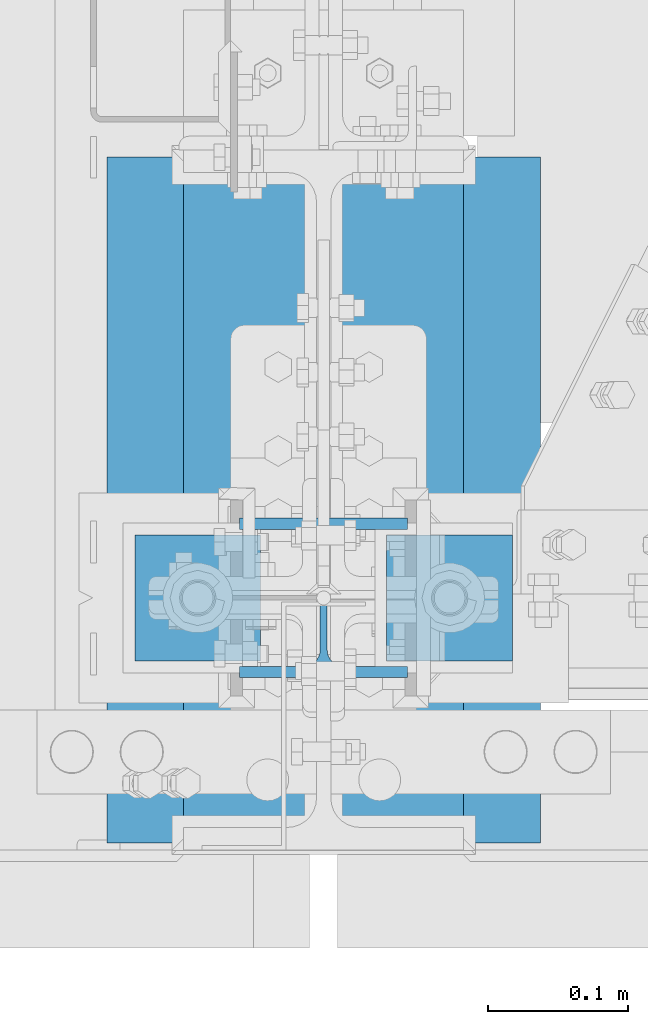
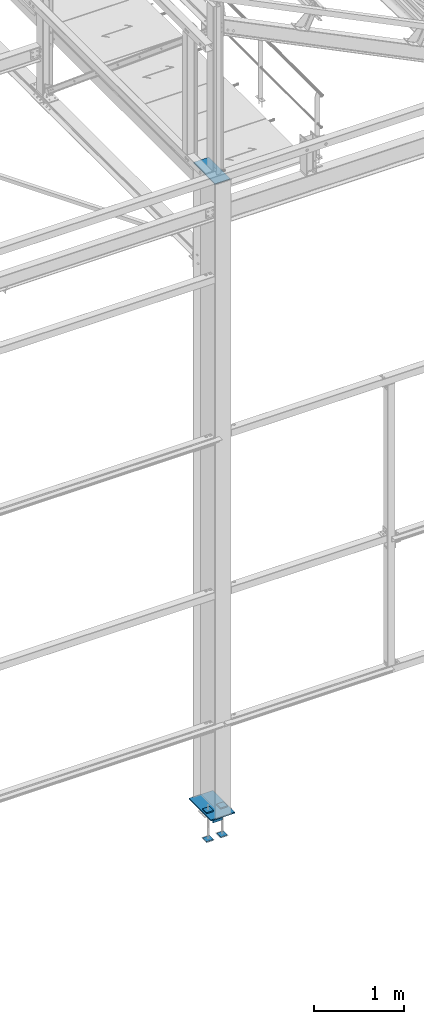
# One storey, part 102 of 496: 7 beams, 2 elements without a shape of their own.
"""IFC2X3 building model written with IfcOpenShell, lengths in millimetres."""

import ifcopenshell
import ifcopenshell.guid

model = None  # the IFC model being written
_history = None  # IfcOwnerHistory: only IFC2X3 demands one
_inside = {}  # id of a spatial element -> (the spatial element, [elements in it])
_under = {}  # id of a project, library or spatial element -> (it, [spatial elements below it])
_declared = {}  # id of a project -> (the project, [libraries it declares])
_typed = {}  # id of a type object -> (the type object, [elements of that type])
_made_of = {}  # id of a material, layer set ... -> (it, [elements and type objects made of it])


def new_model(schema):
    """Start an empty IFC model of exactly this schema.

    Asked for "IFC4X3", IfcOpenShell would pick the latest addendum, in which some entities
    have other attributes; the version numbers below select the first issue.
    IFC2X3 requires an IfcOwnerHistory on every rooted entity: one is made here for all.
    """
    global model, _history
    if schema == "IFC4X3":
        model = ifcopenshell.file(schema_version=(4, 3, 0, 0))
    else:
        model = ifcopenshell.file(schema=schema)
    _inside.clear()
    _under.clear()
    _declared.clear()
    _typed.clear()
    _made_of.clear()
    _history = None
    if model.schema == "IFC2X3":
        org = make("IfcOrganization", Name="unknown")
        user = make(
            "IfcPersonAndOrganization",
            ThePerson=make("IfcPerson", FamilyName="unknown"),
            TheOrganization=org,
        )
        app = make(
            "IfcApplication",
            ApplicationDeveloper=org,
            Version="unknown",
            ApplicationFullName="unknown",
            ApplicationIdentifier="unknown",
        )
        _history = make(
            "IfcOwnerHistory",
            OwningUser=user,
            OwningApplication=app,
            ChangeAction="ADDED",
            CreationDate=0,
        )
    return model


def make(cls, **values):
    """One entity of the class cls with the attributes given. An attribute that is None is left unset."""
    return model.create_entity(
        cls, **{name: value for name, value in values.items() if value is not None}
    )


def rooted(cls, **values):
    """An entity with a GlobalId (a new one), such as an element, a storey or a relation."""
    return make(cls, GlobalId=ifcopenshell.guid.new(), OwnerHistory=_history, **values)


def si_unit(unit_type, name, prefix=None):
    """IfcSIUnit, for example si_unit("LENGTHUNIT", "METRE", prefix="MILLI")."""
    return make("IfcSIUnit", UnitType=unit_type, Prefix=prefix, Name=name)


def assignment(units):
    """IfcUnitAssignment: the units of a project."""
    return None if units is None else make("IfcUnitAssignment", Units=units)


def point(xyz):
    """IfcCartesianPoint."""
    return None if xyz is None else make("IfcCartesianPoint", Coordinates=xyz)


def direction(xyz):
    """IfcDirection."""
    return None if xyz is None else make("IfcDirection", DirectionRatios=xyz)


def frame(location, z_axis=None, x_axis=None):
    """IfcAxis2Placement3D, a coordinate frame: its origin and axes. An axis left out is left unset."""
    return make(
        "IfcAxis2Placement3D",
        Location=point(location),
        Axis=direction(z_axis),
        RefDirection=direction(x_axis),
    )


def frame_2d(location, x_axis=None):
    """IfcAxis2Placement2D, a coordinate frame in the plane: its origin and x axis."""
    return make(
        "IfcAxis2Placement2D", Location=point(location), RefDirection=direction(x_axis)
    )


def origin_with_axes():
    """The frame at (0, 0, 0) with the z axis (0, 0, 1) and the x axis (1, 0, 0) written out."""
    return frame((0.0, 0.0, 0.0), z_axis=(0.0, 0.0, 1.0), x_axis=(1.0, 0.0, 0.0))


def origin_2d_with_axis():
    """The frame at (0, 0) in the plane with the x axis (1, 0) written out."""
    return frame_2d((0.0, 0.0), x_axis=(1.0, 0.0))


def place(relative_to, where):
    """IfcLocalPlacement: puts the frame where relative to a parent placement (None: the world)."""
    return make(
        "IfcLocalPlacement", PlacementRelTo=relative_to, RelativePlacement=where
    )


def context(
    kind, dimensions, precision=None, world=None, true_north=None, identifier=None
):
    """IfcGeometricRepresentationContext, for example the 3D "Model" context."""
    return make(
        "IfcGeometricRepresentationContext",
        ContextIdentifier=identifier,
        ContextType=kind,
        CoordinateSpaceDimension=dimensions,
        Precision=precision,
        WorldCoordinateSystem=world,
        TrueNorth=true_north,
    )


def subcontext(parent, identifier, kind, view, scale=None):
    """IfcGeometricRepresentationSubContext, for example "Body" below "Model"."""
    return make(
        "IfcGeometricRepresentationSubContext",
        ContextIdentifier=identifier,
        ContextType=kind,
        ParentContext=parent,
        TargetScale=scale,
        TargetView=view,
    )


def project(units=None, contexts=None):
    """IfcProject with its units and contexts."""
    return rooted(
        "IfcProject",
        Name="project",
        RepresentationContexts=contexts,
        UnitsInContext=assignment(units),
    )


def spatial(cls, under=None, at=None, **own):
    """A site, building, storey or space (cls), placed at a placement, below another one or the project."""
    s = rooted(cls, ObjectPlacement=at, **own)
    if under is not None:
        _under.setdefault(under.id(), (under, []))[1].append(s)
    return s


def polyline(points):
    """IfcPolyline through the points."""
    return make("IfcPolyline", Points=[point(p) for p in points])


def profile(cls, at=None, kind="AREA", **sizes):
    """A parametric profile (cls). Its sizes go by their IFC names, for example OverallWidth=200.0."""
    return make(cls, ProfileType=kind, Position=at, **sizes)


def rectangle(**sizes):
    """IfcRectangleProfileDef."""
    return profile("IfcRectangleProfileDef", **sizes)


def i_section(**sizes):
    """IfcIShapeProfileDef."""
    return profile("IfcIShapeProfileDef", **sizes)


def outline(outer, holes=None, kind="AREA"):
    """IfcArbitraryClosedProfileDef: a profile drawn as a closed curve; with holes, ...WithVoids."""
    if holes is None:
        return make("IfcArbitraryClosedProfileDef", ProfileType=kind, OuterCurve=outer)
    return make(
        "IfcArbitraryProfileDefWithVoids",
        ProfileType=kind,
        OuterCurve=outer,
        InnerCurves=holes,
    )


def extrude(swept, where, along, depth):
    """IfcExtrudedAreaSolid: the profile swept, set in the frame where, extruded along a direction by depth."""
    return make(
        "IfcExtrudedAreaSolid",
        SweptArea=swept,
        Position=where,
        ExtrudedDirection=direction(along),
        Depth=depth,
    )


def shape(context_of_items, identifier, shape_type, items):
    """IfcShapeRepresentation: the items that make up one representation, for example the "Body"."""
    return make(
        "IfcShapeRepresentation",
        ContextOfItems=context_of_items,
        RepresentationIdentifier=identifier,
        RepresentationType=shape_type,
        Items=items,
    )


def material(Name=None, Category=None):
    """IfcMaterial."""
    return make("IfcMaterial", Name=Name, Category=Category)


def made_of(thing, what):
    """Note that an element or type object is made of a material, layer set ...; save() writes the relation."""
    if what is not None:
        _made_of.setdefault(what.id(), (what, []))[1].append(thing)
    return thing


def type_object(cls, material=None, **own):
    """A type object (cls), such as IfcWallType, which elements share."""
    return made_of(rooted(cls, **own), material)


def element(
    cls,
    number,
    at=None,
    inside=None,
    cuts=None,
    type_object=None,
    material=None,
    context=None,
    identifier="Body",
    shape_type=None,
    held_by="IfcProductDefinitionShape",
    body=None,
    shapes=None,
    **own,
):
    """One element of the class cls, such as IfcWall. Its Tag is "e" and its number.

    at: its placement. inside: the storey or other place that contains it. cuts: it is an
    opening in that element (IfcRelVoidsElement). A single representation is given by context,
    identifier, shape_type and body (its items); several are given by shapes. held_by: the class
    of the entity that holds the representations. save() writes the other relations.
    """
    e = rooted(cls, Tag="e%d" % number, ObjectPlacement=at, **own)
    if body is not None:
        shapes = [shape(context, identifier, shape_type, body)]
    if shapes is not None:
        e.Representation = make(held_by, Representations=shapes)
    if inside is not None:
        _inside.setdefault(inside.id(), (inside, []))[1].append(e)
    if cuts is not None:
        rooted(
            "IfcRelVoidsElement", RelatingBuildingElement=cuts, RelatedOpeningElement=e
        )
    if type_object is not None:
        _typed.setdefault(type_object.id(), (type_object, []))[1].append(e)
    return made_of(e, material)


def aggregate(whole, parts):
    """IfcRelAggregates: a whole, such as a stair, and the parts it consists of."""
    return rooted("IfcRelAggregates", RelatingObject=whole, RelatedObjects=parts)


def save(model, path):
    """Write the relations noted so far, then the file.

    IfcRelAggregates (storeys below a building ...), IfcRelContainedInSpatialStructure (elements
    in a storey), IfcRelDefinesByType, IfcRelAssociatesMaterial and IfcRelDeclares: one each for
    every whole, place, type object, material and project.
    """
    for whole, parts in _under.values():
        aggregate(whole, parts)
    for where, things in _inside.values():
        rooted(
            "IfcRelContainedInSpatialStructure",
            RelatedElements=things,
            RelatingStructure=where,
        )
    for kind, things in _typed.values():
        rooted("IfcRelDefinesByType", RelatedObjects=things, RelatingType=kind)
    for what, things in _made_of.values():
        rooted("IfcRelAssociatesMaterial", RelatedObjects=things, RelatingMaterial=what)
    for by, libraries in _declared.values():
        rooted("IfcRelDeclares", RelatingContext=by, RelatedDefinitions=libraries)
    model.write(path)


model = new_model("IFC2X3")

# Units and contexts
model_context = context("Model", 3, precision=1e-05, world=origin_with_axes())
body_context = subcontext(model_context, "Body", "Model", "MODEL_VIEW")
ifc_project = project(units=[si_unit("LENGTHUNIT", "METRE", prefix="MILLI"), si_unit("AREAUNIT", "SQUARE_METRE"), si_unit("VOLUMEUNIT", "CUBIC_METRE"), si_unit("MASSUNIT", "GRAM", prefix="KILO"), si_unit("TIMEUNIT", "SECOND"), si_unit("PLANEANGLEUNIT", "RADIAN"), si_unit("SOLIDANGLEUNIT", "STERADIAN"), si_unit("THERMODYNAMICTEMPERATUREUNIT", "DEGREE_CELSIUS"), si_unit("LUMINOUSINTENSITYUNIT", "LUMEN")], contexts=[model_context])

# Site, building, storey
site_placement = place(None, origin_with_axes())
site = spatial("IfcSite", under=ifc_project, at=site_placement, CompositionType="ELEMENT")
building_placement = place(site_placement, origin_with_axes())
building = spatial("IfcBuilding", under=site, at=building_placement, Name="Undefined", CompositionType="ELEMENT")
storey_placement = place(building_placement, origin_with_axes())
storey = spatial("IfcBuildingStorey", under=building, at=storey_placement, Name="Undefined", CompositionType="ELEMENT", Elevation=0.0)

# Assembly, beams
assembly_1_placement = place(storey_placement, origin_with_axes())
assembly_1 = element("IfcElementAssembly", 1, at=assembly_1_placement, inside=storey, Name="POTEAU", AssemblyPlace="NOTDEFINED", PredefinedType="NOTDEFINED")
ifc_material_1 = material(Name="Undefined/S235-E24")
beam_type_1 = type_object("IfcBeamType", PredefinedType="NOTDEFINED")
beam_1_placement = place(assembly_1_placement, frame((34280.0, 312.0, 8445.0), z_axis=(1.0, 0.0, 0.0), x_axis=(0.0, -1.0, 0.0)))
beam_1 = element("IfcBeam", 2, at=beam_1_placement, type_object=beam_type_1, material=ifc_material_1, context=body_context, shape_type="SweptSolid", body=[
    extrude(rectangle(XDim=10.0, YDim=200.0, at=origin_2d_with_axis()), frame((484.0, 0.0, 0.0), z_axis=(-1.0, 0.0, 0.0), x_axis=(0.0, -1.0, 0.0)), (0.0, 0.0, 1.0), 484.0),
])
beam_type_2 = type_object("IfcBeamType", PredefinedType="NOTDEFINED")
beam_2_placement = place(assembly_1_placement, frame((34434.9971504447, 70.0, -192.5), z_axis=(0.0, -1.0, 0.0), x_axis=(-1.0, 0.0, 0.0)))
beam_2 = element("IfcBeam", 3, at=beam_2_placement, type_object=beam_type_2, material=ifc_material_1, context=body_context, shape_type="SweptSolid", body=[
    extrude(rectangle(XDim=15.0, YDim=490.0, at=origin_2d_with_axis()), frame((310.0, 0.0, 0.0), z_axis=(-1.0, 0.0, 0.0), x_axis=(0.0, -1.0, 0.0)), (0.0, 0.0, 1.0), 310.0),
])
aggregate(assembly_1, [beam_2, beam_1])

assembly_2_placement = place(storey_placement, origin_with_axes())
assembly_2 = element("IfcElementAssembly", 4, at=assembly_2_placement, inside=storey, Name="PS24", AssemblyPlace="NOTDEFINED", PredefinedType="NOTDEFINED")
beam_type_3 = type_object("IfcBeamType", PredefinedType="NOTDEFINED")
beam_3_placement = place(assembly_2_placement, frame((34234.9971504447, -45.0, -177.5), z_axis=(0.0, 0.0, 1.0), x_axis=(0.0, 1.0, 0.0)))
beam_3 = element("IfcBeam", 5, at=beam_3_placement, type_object=beam_type_3, material=ifc_material_1, context=body_context, shape_type="SweptSolid", body=[
    extrude(outline(polyline([(0.0, 0.0), (90.0, 0.0), (90.0, 90.0), (0.0, 90.0), (0.0, 0.0)])), frame((0.0, 0.0, -7.5), z_axis=(0.0, 0.0, 1.0), x_axis=(1.0, 0.0, 0.0)), (0.0, 0.0, 1.0), 15.0),
])
beam_4_placement = place(assembly_2_placement, frame((34414.9971504447, -45.0, -177.5), z_axis=(0.0, 0.0, 1.0), x_axis=(0.0, 1.0, 0.0)))
beam_4 = element("IfcBeam", 6, at=beam_4_placement, type_object=beam_type_3, material=ifc_material_1, context=body_context, shape_type="SweptSolid", body=[
    extrude(outline(polyline([(0.0, 0.0), (90.0, 0.0), (90.0, 90.0), (0.0, 90.0), (0.0, 0.0)])), frame((0.0, 0.0, -7.5), z_axis=(0.0, 0.0, 1.0), x_axis=(1.0, 0.0, 0.0)), (0.0, 0.0, 1.0), 15.0),
])
beam_5_placement = place(assembly_2_placement, frame((34234.9971504447, -45.0, -572.5), z_axis=(0.0, 0.0, 1.0), x_axis=(0.0, 1.0, 0.0)))
beam_5 = element("IfcBeam", 7, at=beam_5_placement, type_object=beam_type_3, material=ifc_material_1, context=body_context, shape_type="SweptSolid", body=[
    extrude(outline(polyline([(0.0, 0.0), (90.0, 0.0), (90.0, 90.0), (0.0, 90.0), (0.0, 0.0)])), frame((0.0, 0.0, -7.5), z_axis=(0.0, 0.0, 1.0), x_axis=(1.0, 0.0, 0.0)), (0.0, 0.0, 1.0), 15.0),
])
beam_6_placement = place(assembly_2_placement, frame((34414.9971504447, -45.0, -572.5), z_axis=(0.0, 0.0, 1.0), x_axis=(0.0, 1.0, 0.0)))
beam_6 = element("IfcBeam", 8, at=beam_6_placement, type_object=beam_type_3, material=ifc_material_1, context=body_context, shape_type="SweptSolid", body=[
    extrude(outline(polyline([(0.0, 0.0), (90.0, 0.0), (90.0, 90.0), (0.0, 90.0), (0.0, 0.0)])), frame((0.0, 0.0, -7.5), z_axis=(0.0, 0.0, 1.0), x_axis=(1.0, 0.0, 0.0)), (0.0, 0.0, 1.0), 15.0),
])
ifc_material_2 = material(Name="Undefined/S275-E28")
beam_type_4 = type_object("IfcBeamType", Name="HEA120", PredefinedType="NOTDEFINED")
beam_7_placement = place(assembly_2_placement, frame((34280.0000000734, 0.0, -210.0), z_axis=(0.0, -1.0, 0.0), x_axis=(0.0, 0.0, -1.0)))
beam_7 = element("IfcBeam", 9, at=beam_7_placement, type_object=beam_type_4, material=ifc_material_2, ObjectType="HEA120", context=body_context, shape_type="SweptSolid", body=[
    extrude(i_section(OverallWidth=120.0, OverallDepth=114.0, WebThickness=5.0, FlangeThickness=8.0, FilletRadius=12.0, at=origin_2d_with_axis()), frame((120.0, 0.0, 0.0), z_axis=(-1.0, 0.0, 0.0), x_axis=(0.0, -1.0, 0.0)), (0.0, 0.0, 1.0), 120.0),
])
aggregate(assembly_2, [beam_7, beam_3, beam_4, beam_5, beam_6])

save(model, "model.ifc")
